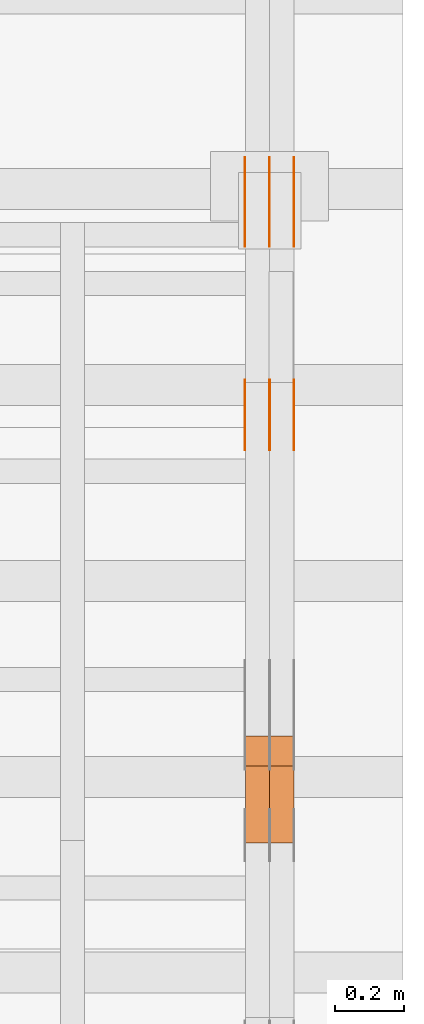
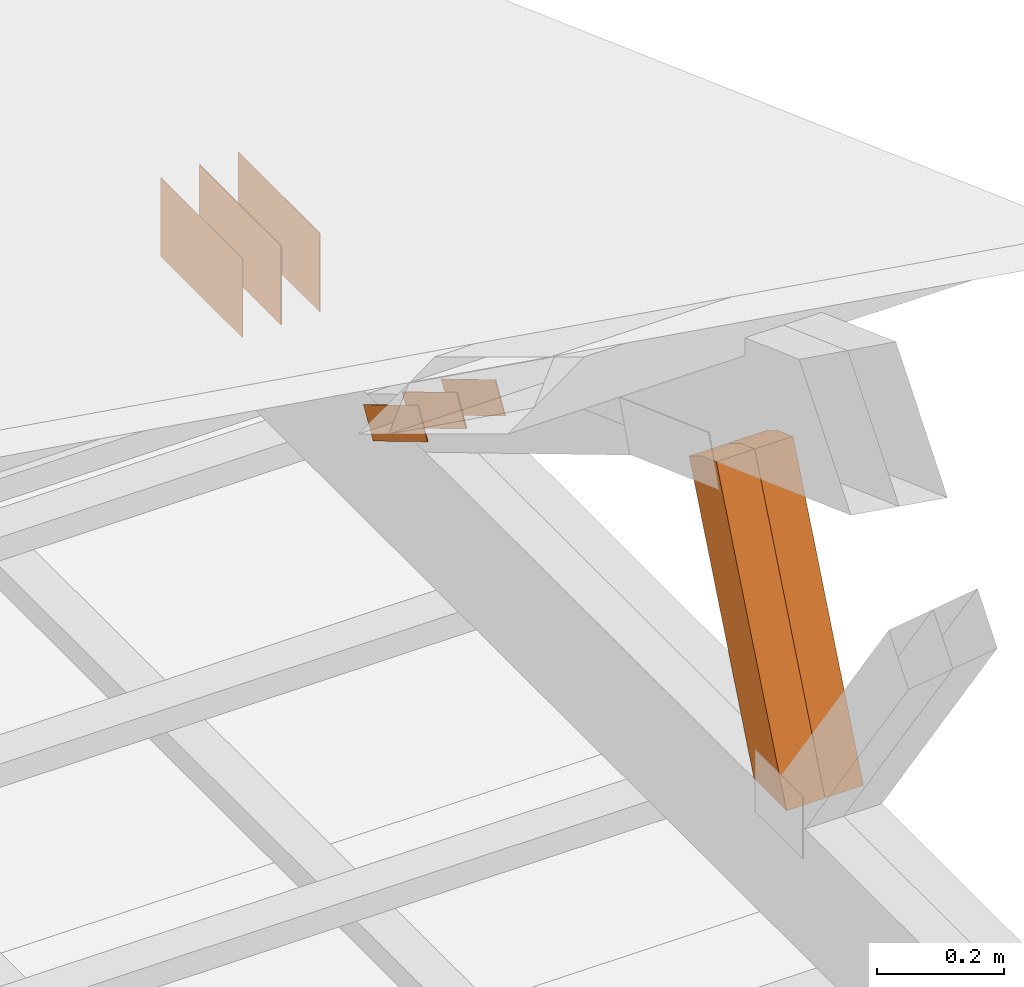
# One storey, part 178 of 189: 10 proxies.
"""IFC2X3 building model written with IfcOpenShell, lengths in millimetres."""

from ifc_helpers import new_model, entity, si_unit, converted_unit, derived_unit, direction, frame, origin, origin_2d_with_axis, place, context, subcontext, project, spatial, polyline, rectangle, outline, extrude, source, transform, mapped, material, type_object, type_shapes, element, save


model = new_model("IFC2X3")

# Units and contexts
model_context = context("Model", 3, precision=0.01, world=origin(), true_north=direction((6.12303176911189e-17, 1.0)))
body_context = subcontext(model_context, "Body", "Model", "MODEL_VIEW")
ifc_project = project(units=[si_unit("LENGTHUNIT", "METRE", prefix="MILLI"), si_unit("AREAUNIT", "SQUARE_METRE"), si_unit("VOLUMEUNIT", "CUBIC_METRE"), converted_unit("PLANEANGLEUNIT", "DEGREE", entity("IfcRatioMeasure", 0.0174532925199433), si_unit("PLANEANGLEUNIT", "RADIAN"), dimensions=[0, 0, 0, 0, 0, 0, 0]), si_unit("MASSUNIT", "GRAM", prefix="KILO"), derived_unit("MASSDENSITYUNIT", [(si_unit("MASSUNIT", "GRAM", prefix="KILO"), 1), (si_unit("LENGTHUNIT", "METRE"), -3)]), si_unit("TIMEUNIT", "SECOND"), si_unit("FREQUENCYUNIT", "HERTZ"), si_unit("THERMODYNAMICTEMPERATUREUNIT", "DEGREE_CELSIUS"), derived_unit("THERMALTRANSMITTANCEUNIT", [(si_unit("MASSUNIT", "GRAM", prefix="KILO"), 1), (si_unit("THERMODYNAMICTEMPERATUREUNIT", "KELVIN"), -1), (si_unit("TIMEUNIT", "SECOND"), -3)]), derived_unit("VOLUMETRICFLOWRATEUNIT", [(si_unit("LENGTHUNIT", "METRE"), 3), (si_unit("TIMEUNIT", "SECOND"), -1)]), si_unit("ELECTRICCURRENTUNIT", "AMPERE"), si_unit("ELECTRICVOLTAGEUNIT", "VOLT"), si_unit("POWERUNIT", "WATT"), si_unit("FORCEUNIT", "NEWTON"), si_unit("ILLUMINANCEUNIT", "LUX"), si_unit("LUMINOUSFLUXUNIT", "LUMEN"), si_unit("LUMINOUSINTENSITYUNIT", "CANDELA"), derived_unit("USERDEFINED", [(si_unit("MASSUNIT", "GRAM", prefix="KILO"), -1), (si_unit("LENGTHUNIT", "METRE"), -2), (si_unit("TIMEUNIT", "SECOND"), 3), (si_unit("LUMINOUSFLUXUNIT", "LUMEN"), 1)]), derived_unit("LINEARVELOCITYUNIT", [(si_unit("LENGTHUNIT", "METRE"), 1), (si_unit("TIMEUNIT", "SECOND"), -1)]), si_unit("PRESSUREUNIT", "PASCAL"), derived_unit("USERDEFINED", [(si_unit("LENGTHUNIT", "METRE"), -2), (si_unit("MASSUNIT", "GRAM", prefix="KILO"), 1), (si_unit("TIMEUNIT", "SECOND"), -2)])], contexts=[model_context])

# Site, building, storey
site_placement = place(None, origin())
site = spatial("IfcSite", under=ifc_project, at=site_placement, CompositionType="ELEMENT")
building_placement = place(site_placement, origin())
building = spatial("IfcBuilding", under=site, at=building_placement, CompositionType="ELEMENT")
storey_placement = place(building_placement, origin())
storey = spatial("IfcBuildingStorey", under=building, at=storey_placement, Name="Default", CompositionType="ELEMENT", Elevation=0.0)

# Proxies
ifc_material_1 = material(Name="IfcSurfaceStyle #277204")
building_element_proxy_type_1 = type_object("IfcBuildingElementProxyType", PredefinedType="NOTDEFINED", material=ifc_material_1)
shared_shape_1 = source(origin(), body_context, "Body", "SweptSolid", [
    extrude(outline(polyline([(-100.000014621824, -30.0000173081658), (100.000025679578, -30.0000173081658), (100.000010707989, 30.0000173081658), (-100.000021765743, 30.0000173081658), (-100.000014621824, -30.0000173081658)])), frame((100.000025679578, 30.0000173081658, 0.0), z_axis=(0.0, 0.0, 1.0), x_axis=(-1.0, 0.0, 0.0)), (0.0, 0.0, 1.0), 1.3),
])
type_shapes(building_element_proxy_type_1, [shared_shape_1])
proxy_1_placement = place(building_placement, frame((49841.3, 28812.2744732883, 167.948789809131), z_axis=(-1.0, 0.0, 0.0), x_axis=(0.0, -0.858392121304013, 0.51299411895576)))
element("IfcBuildingElementProxy", 1, at=proxy_1_placement, inside=storey, type_object=building_element_proxy_type_1, material=ifc_material_1, context=body_context, shape_type="MappedRepresentation", body=[
    mapped(shared_shape_1, transform((0.0, 0.0, 0.0), scale=1.0)),
])
ifc_material_2 = material(Name="IfcSurfaceStyle #277147")
building_element_proxy_type_2 = type_object("IfcBuildingElementProxyType", PredefinedType="NOTDEFINED", material=ifc_material_2)
shared_shape_2 = source(origin(), body_context, "Body", "SweptSolid", [
    extrude(outline(polyline([(-100.000014621824, -30.0000173081658), (100.000025679578, -30.0000173081658), (100.000010707989, 30.0000173081658), (-100.000021765743, 30.0000173081658), (-100.000014621824, -30.0000173081658)])), frame((100.000025679578, 30.0000173081658, 0.0), z_axis=(0.0, 0.0, 1.0), x_axis=(-1.0, 0.0, 0.0)), (0.0, 0.0, 1.0), 1.29999999999998),
])
type_shapes(building_element_proxy_type_2, [shared_shape_2])
proxy_2_placement = place(building_placement, frame((49770.0, 28812.2744732883, 167.948789809131), z_axis=(-1.0, 0.0, 0.0), x_axis=(0.0, -0.858392121304013, 0.51299411895576)))
element("IfcBuildingElementProxy", 2, at=proxy_2_placement, inside=storey, type_object=building_element_proxy_type_2, material=ifc_material_2, context=body_context, shape_type="MappedRepresentation", body=[
    mapped(shared_shape_2, transform((0.0, 0.0, 0.0), scale=1.0)),
])
ifc_material_3 = material(Name="IfcSurfaceStyle #277090")
building_element_proxy_type_3 = type_object("IfcBuildingElementProxyType", PredefinedType="NOTDEFINED", material=ifc_material_3)
shared_shape_3 = source(origin(), body_context, "Body", "SweptSolid", [
    extrude(outline(polyline([(-100.000014621824, -30.0000173081658), (100.000025679578, -30.0000173081658), (100.000010707989, 30.0000173081658), (-100.000021765743, 30.0000173081658), (-100.000014621824, -30.0000173081658)])), frame((100.000025679578, 30.0000173081658, 0.0), z_axis=(0.0, 0.0, 1.0), x_axis=(-1.0, 0.0, 0.0)), (0.0, 0.0, 1.0), 1.29999999999998),
])
type_shapes(building_element_proxy_type_3, [shared_shape_3])
proxy_3_placement = place(building_placement, frame((49771.3, 28812.2744732883, 167.948789809131), z_axis=(-1.0, 0.0, 0.0), x_axis=(0.0, -0.858392121304013, 0.51299411895576)))
element("IfcBuildingElementProxy", 3, at=proxy_3_placement, inside=storey, type_object=building_element_proxy_type_3, material=ifc_material_3, context=body_context, shape_type="MappedRepresentation", body=[
    mapped(shared_shape_3, transform((0.0, 0.0, 0.0), scale=1.0)),
])
ifc_material_4 = material(Name="IfcSurfaceStyle #277033")
building_element_proxy_type_4 = type_object("IfcBuildingElementProxyType", PredefinedType="NOTDEFINED", material=ifc_material_4)
shared_shape_4 = source(origin(), body_context, "Body", "SweptSolid", [
    extrude(outline(polyline([(-100.000014621824, -30.0000173081658), (100.000025679578, -30.0000173081658), (100.000010707989, 30.0000173081658), (-100.000021765743, 30.0000173081658), (-100.000014621824, -30.0000173081658)])), frame((100.000025679578, 30.0000173081658, 0.0), z_axis=(0.0, 0.0, 1.0), x_axis=(-1.0, 0.0, 0.0)), (0.0, 0.0, 1.0), 1.29999999999999),
])
type_shapes(building_element_proxy_type_4, [shared_shape_4])
proxy_4_placement = place(building_placement, frame((49700.0, 28812.2744732883, 167.948789809131), z_axis=(-1.0, 0.0, 0.0), x_axis=(0.0, -0.858392121304013, 0.51299411895576)))
element("IfcBuildingElementProxy", 4, at=proxy_4_placement, inside=storey, type_object=building_element_proxy_type_4, material=ifc_material_4, context=body_context, shape_type="MappedRepresentation", body=[
    mapped(shared_shape_4, transform((0.0, 0.0, 0.0), scale=1.0)),
])
ifc_material_5 = material(Name="IfcSurfaceStyle #276748")
building_element_proxy_type_5 = type_object("IfcBuildingElementProxyType", PredefinedType="NOTDEFINED", material=ifc_material_5)
shared_shape_5 = source(origin(), body_context, "Body", "SweptSolid", [
    extrude(rectangle(XDim=258.000001907349, YDim=151.999992370605, at=origin_2d_with_axis()), frame((129.000001782157, 75.9999961853027, 0.0), z_axis=(0.0, 0.0, 1.0), x_axis=(-1.0, 0.0, 0.0)), (0.0, 0.0, 1.0), 0.999999999999984),
])
type_shapes(building_element_proxy_type_5, [shared_shape_5])
proxy_5_placement = place(building_placement, frame((49841.0, 29483.7634609878, 116.138221740723), z_axis=(-1.0, 0.0, 0.0), x_axis=(0.0, -1.0, 0.0)))
element("IfcBuildingElementProxy", 5, at=proxy_5_placement, inside=storey, type_object=building_element_proxy_type_5, material=ifc_material_5, Name="GNT100S 152x258", context=body_context, shape_type="MappedRepresentation", body=[
    mapped(shared_shape_5, transform((0.0, 0.0, 0.0), scale=1.0)),
])
ifc_material_6 = material(Name="IfcSurfaceStyle #276691")
building_element_proxy_type_6 = type_object("IfcBuildingElementProxyType", PredefinedType="NOTDEFINED", material=ifc_material_6)
shared_shape_6 = source(origin(), body_context, "Body", "SweptSolid", [
    extrude(rectangle(XDim=258.000001907349, YDim=151.999992370605, at=origin_2d_with_axis()), frame((129.000001782157, 75.9999961853027, 0.0), z_axis=(0.0, 0.0, 1.0), x_axis=(-1.0, 0.0, 0.0)), (0.0, 0.0, 1.0), 0.999999999999984),
])
type_shapes(building_element_proxy_type_6, [shared_shape_6])
proxy_6_placement = place(building_placement, frame((49770.0, 29483.7634609878, 116.138221740723), z_axis=(-1.0, 0.0, 0.0), x_axis=(0.0, -1.0, 0.0)))
element("IfcBuildingElementProxy", 6, at=proxy_6_placement, inside=storey, type_object=building_element_proxy_type_6, material=ifc_material_6, Name="GNT100S 152x258", context=body_context, shape_type="MappedRepresentation", body=[
    mapped(shared_shape_6, transform((0.0, 0.0, 0.0), scale=1.0)),
])
ifc_material_7 = material(Name="IfcSurfaceStyle #276634")
building_element_proxy_type_7 = type_object("IfcBuildingElementProxyType", PredefinedType="NOTDEFINED", material=ifc_material_7)
shared_shape_7 = source(origin(), body_context, "Body", "SweptSolid", [
    extrude(rectangle(XDim=258.000001907349, YDim=151.999992370605, at=origin_2d_with_axis()), frame((129.000001782157, 75.9999961853027, 0.0), z_axis=(0.0, 0.0, 1.0), x_axis=(-1.0, 0.0, 0.0)), (0.0, 0.0, 1.0), 0.999999999999984),
])
type_shapes(building_element_proxy_type_7, [shared_shape_7])
proxy_7_placement = place(building_placement, frame((49771.0, 29483.7634609878, 116.138221740723), z_axis=(-1.0, 0.0, 0.0), x_axis=(0.0, -1.0, 0.0)))
element("IfcBuildingElementProxy", 7, at=proxy_7_placement, inside=storey, type_object=building_element_proxy_type_7, material=ifc_material_7, Name="GNT100S 152x258", context=body_context, shape_type="MappedRepresentation", body=[
    mapped(shared_shape_7, transform((0.0, 0.0, 0.0), scale=1.0)),
])
ifc_material_8 = material(Name="IfcSurfaceStyle #276577")
building_element_proxy_type_8 = type_object("IfcBuildingElementProxyType", PredefinedType="NOTDEFINED", material=ifc_material_8)
shared_shape_8 = source(origin(), body_context, "Body", "SweptSolid", [
    extrude(rectangle(XDim=258.000001907349, YDim=151.999992370605, at=origin_2d_with_axis()), frame((129.000001782157, 75.9999961853027, 0.0), z_axis=(0.0, 0.0, 1.0), x_axis=(-1.0, 0.0, 0.0)), (0.0, 0.0, 1.0), 0.999999999999984),
])
type_shapes(building_element_proxy_type_8, [shared_shape_8])
proxy_8_placement = place(building_placement, frame((49700.0, 29483.7634609878, 116.138221740723), z_axis=(-1.0, 0.0, 0.0), x_axis=(0.0, -1.0, 0.0)))
element("IfcBuildingElementProxy", 8, at=proxy_8_placement, inside=storey, type_object=building_element_proxy_type_8, material=ifc_material_8, Name="GNT100S 152x258", context=body_context, shape_type="MappedRepresentation", body=[
    mapped(shared_shape_8, transform((0.0, 0.0, 0.0), scale=1.0)),
])
ifc_material_9 = material(Name="IfcSurfaceStyle #270340")
building_element_proxy_type_9 = type_object("IfcBuildingElementProxyType", Name="T1-W15 270338", PredefinedType="NOTDEFINED", material=ifc_material_9)
shared_shape_9 = source(origin(), body_context, "Body", "SweptSolid", [
    extrude(outline(polyline([(-356.314733086722, -47.5000181042257), (225.500284389883, -47.5000181042257), (227.502094104438, -2.00397075419828e-05), (220.445344962296, 47.5000281240794), (-317.132990369895, 47.5000281240795), (-356.314733086722, -47.5000181042257)])), frame((227.502118521083, 47.5000281240794, 0.0), z_axis=(0.0, 0.0, 1.0), x_axis=(-1.0, 0.0, 0.0)), (0.0, 0.0, 1.0), 70.0),
])
type_shapes(building_element_proxy_type_9, [shared_shape_9])
proxy_9_placement = place(building_placement, frame((49840.0, 27820.3452927615, 748.492381554869), z_axis=(-1.0, 0.0, 0.0), x_axis=(0.0, -0.38128326679549, -0.9244582578255)))
element("IfcBuildingElementProxy", 9, at=proxy_9_placement, inside=storey, type_object=building_element_proxy_type_9, material=ifc_material_9, Name="T1-W15", context=body_context, shape_type="MappedRepresentation", body=[
    mapped(shared_shape_9, transform((0.0, 0.0, 0.0), scale=1.0)),
])
ifc_material_10 = material(Name="IfcSurfaceStyle #270274")
building_element_proxy_type_10 = type_object("IfcBuildingElementProxyType", Name="T1-W15 270272", PredefinedType="NOTDEFINED", material=ifc_material_10)
shared_shape_10 = source(origin(), body_context, "Body", "SweptSolid", [
    extrude(outline(polyline([(-356.314733086722, -47.5000181042257), (225.500284389883, -47.5000181042257), (227.502094104438, -2.00397075419828e-05), (220.445344962296, 47.5000281240794), (-317.132990369895, 47.5000281240795), (-356.314733086722, -47.5000181042257)])), frame((227.502118521083, 47.5000281240794, 0.0), z_axis=(0.0, 0.0, 1.0), x_axis=(-1.0, 0.0, 0.0)), (0.0, 0.0, 1.0), 70.0),
])
type_shapes(building_element_proxy_type_10, [shared_shape_10])
proxy_10_placement = place(building_placement, frame((49770.0, 27820.3452927615, 748.492381554869), z_axis=(-1.0, 0.0, 0.0), x_axis=(0.0, -0.38128326679549, -0.9244582578255)))
element("IfcBuildingElementProxy", 10, at=proxy_10_placement, inside=storey, type_object=building_element_proxy_type_10, material=ifc_material_10, Name="T1-W15", context=body_context, shape_type="MappedRepresentation", body=[
    mapped(shared_shape_10, transform((0.0, 0.0, 0.0), scale=1.0)),
])

save(model, "model.ifc")
